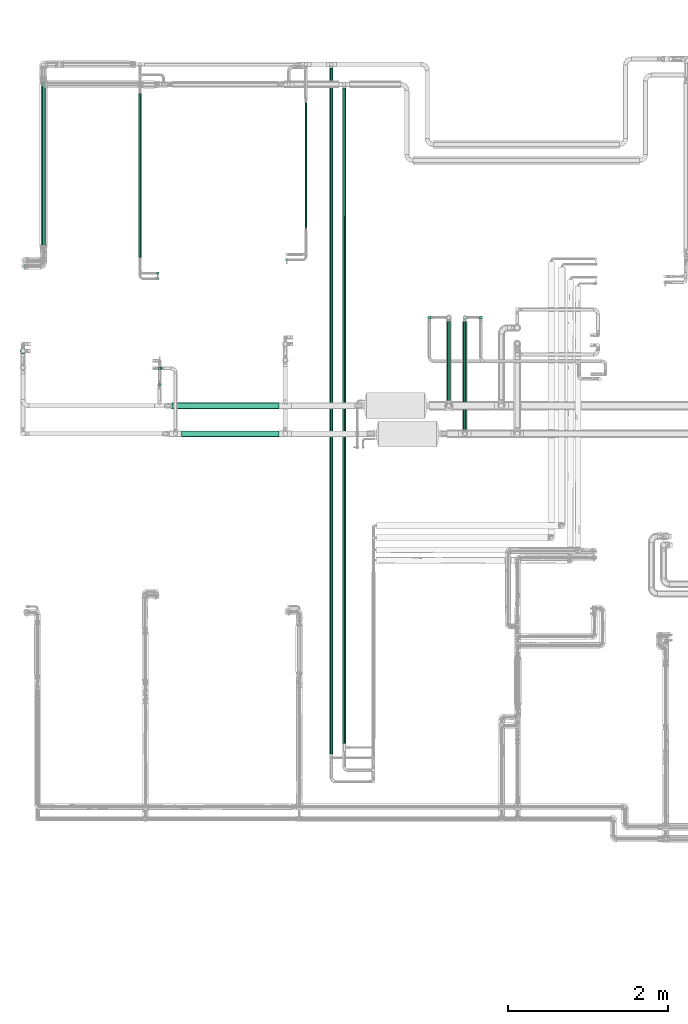
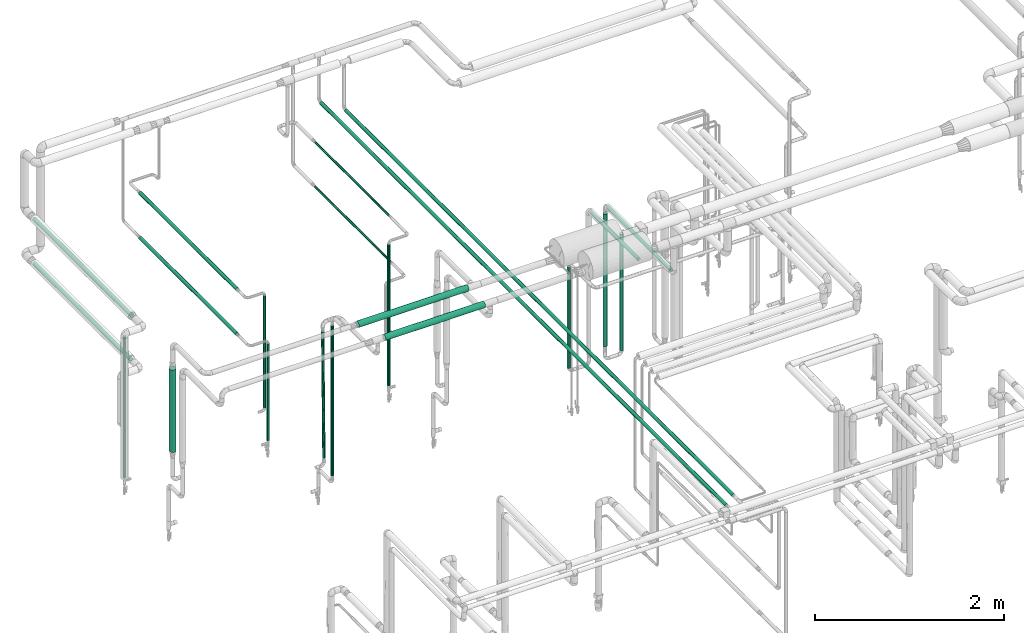
# One storey, part 524 of 827: 22 flow segments.
"""IFC2X3 building model written with IfcOpenShell, lengths in millimetres."""

from ifc_helpers import new_model, entity, si_unit, converted_unit, derived_unit, direction, frame, origin, origin_2d_with_axis, place, context, subcontext, project, spatial, circle, extrude, type_object, element, save


model = new_model("IFC2X3")

# Units and contexts
model_context = context("Model", 3, precision=0.01, world=origin(), true_north=direction((6.12303176911189e-17, 1.0)))
body_context = subcontext(model_context, "Body", "Model", "MODEL_VIEW")
ifc_project = project(units=[si_unit("LENGTHUNIT", "METRE", prefix="MILLI"), si_unit("AREAUNIT", "SQUARE_METRE"), si_unit("VOLUMEUNIT", "CUBIC_METRE"), converted_unit("PLANEANGLEUNIT", "DEGREE", entity("IfcRatioMeasure", 0.0174532925199433), si_unit("PLANEANGLEUNIT", "RADIAN"), dimensions=[0, 0, 0, 0, 0, 0, 0]), si_unit("MASSUNIT", "GRAM", prefix="KILO"), derived_unit("MASSDENSITYUNIT", [(si_unit("MASSUNIT", "GRAM", prefix="KILO"), 1), (si_unit("LENGTHUNIT", "METRE"), -3)]), derived_unit("MOMENTOFINERTIAUNIT", [(si_unit("LENGTHUNIT", "METRE"), 4)]), si_unit("TIMEUNIT", "SECOND"), si_unit("FREQUENCYUNIT", "HERTZ"), si_unit("THERMODYNAMICTEMPERATUREUNIT", "DEGREE_CELSIUS"), derived_unit("THERMALTRANSMITTANCEUNIT", [(si_unit("MASSUNIT", "GRAM", prefix="KILO"), 1), (si_unit("THERMODYNAMICTEMPERATUREUNIT", "KELVIN"), -1), (si_unit("TIMEUNIT", "SECOND"), -3)]), derived_unit("VOLUMETRICFLOWRATEUNIT", [(si_unit("LENGTHUNIT", "METRE"), 3), (si_unit("TIMEUNIT", "SECOND"), -1)]), derived_unit("MASSFLOWRATEUNIT", [(si_unit("MASSUNIT", "GRAM", prefix="KILO"), 1), (si_unit("TIMEUNIT", "SECOND"), -1)]), derived_unit("ROTATIONALFREQUENCYUNIT", [(si_unit("TIMEUNIT", "SECOND"), -1)]), si_unit("ELECTRICCURRENTUNIT", "AMPERE"), si_unit("ELECTRICVOLTAGEUNIT", "VOLT"), si_unit("POWERUNIT", "WATT"), si_unit("FORCEUNIT", "NEWTON", prefix="KILO"), si_unit("ILLUMINANCEUNIT", "LUX"), si_unit("LUMINOUSFLUXUNIT", "LUMEN"), si_unit("LUMINOUSINTENSITYUNIT", "CANDELA"), derived_unit("USERDEFINED", [(si_unit("MASSUNIT", "GRAM", prefix="KILO"), -1), (si_unit("LENGTHUNIT", "METRE"), -2), (si_unit("TIMEUNIT", "SECOND"), 3), (si_unit("LUMINOUSFLUXUNIT", "LUMEN"), 1)]), derived_unit("LINEARVELOCITYUNIT", [(si_unit("LENGTHUNIT", "METRE"), 1), (si_unit("TIMEUNIT", "SECOND"), -1)]), si_unit("PRESSUREUNIT", "PASCAL"), derived_unit("USERDEFINED", [(si_unit("LENGTHUNIT", "METRE"), -2), (si_unit("MASSUNIT", "GRAM", prefix="KILO"), 1), (si_unit("TIMEUNIT", "SECOND"), -2)]), derived_unit("LINEARFORCEUNIT", [(si_unit("MASSUNIT", "GRAM", prefix="KILO"), 1), (si_unit("LENGTHUNIT", "METRE"), 1), (si_unit("TIMEUNIT", "SECOND"), -2), (si_unit("LENGTHUNIT", "METRE"), -1)]), derived_unit("PLANARFORCEUNIT", [(si_unit("MASSUNIT", "GRAM", prefix="KILO"), 1), (si_unit("LENGTHUNIT", "METRE"), 1), (si_unit("TIMEUNIT", "SECOND"), -2), (si_unit("LENGTHUNIT", "METRE"), -2)])], contexts=[model_context])

# Site, building, storey
site_placement = place(None, origin())
site = spatial("IfcSite", under=ifc_project, at=site_placement, CompositionType="ELEMENT")
building_placement = place(site_placement, origin())
building = spatial("IfcBuilding", under=site, at=building_placement, CompositionType="ELEMENT")
storey_placement = place(building_placement, frame((0.0, 0.0, 28200.0)))
storey = spatial("IfcBuildingStorey", under=building, at=storey_placement, Name="08", CompositionType="ELEMENT", Elevation=28200.0)

# Flow segments
pipe_segment_type = type_object("IfcPipeSegmentType", PredefinedType="NOTDEFINED")
flow_segment_1_placement = place(storey_placement, frame((11756.87, 16476.3, 407.5)))
element("IfcFlowSegment", 1, at=flow_segment_1_placement, inside=storey, type_object=pipe_segment_type, context=body_context, shape_type="SweptSolid", body=[
    extrude(circle(Radius=16.75, at=origin_2d_with_axis()), frame((18.35, 18.35, 0.0), z_axis=(0.0, 0.0, 1.0), x_axis=(-1.0, 0.0, 0.0)), (0.0, 0.0, 1.0), 1824.7853679055),
])
flow_segment_2_placement = place(storey_placement, frame((13415.62, 16387.05, 788.0)))
element("IfcFlowSegment", 2, at=flow_segment_2_placement, inside=storey, type_object=pipe_segment_type, context=body_context, shape_type="SweptSolid", body=[
    extrude(circle(Radius=16.75, at=origin_2d_with_axis()), frame((18.35, 18.35, 0.0), z_axis=(0.0, 1.18738116204354e-05, 1.0), x_axis=(-1.0, 0.0, 0.0)), (0.0, 0.0, 1.0), 1444.28268558114),
])
flow_segment_3_placement = place(storey_placement, frame((15026.3, 16554.55, 407.5)))
element("IfcFlowSegment", 3, at=flow_segment_3_placement, inside=storey, type_object=pipe_segment_type, context=body_context, shape_type="SweptSolid", body=[
    extrude(circle(Radius=16.75, at=origin_2d_with_axis()), frame((18.35, 18.35, 0.0), z_axis=(0.0, 0.0, 1.0), x_axis=(-1.0, 0.0, 0.0)), (0.0, 0.0, 1.0), 1819.95737347912),
])
flow_segment_4_placement = place(storey_placement, frame((13415.62, 16319.55, 407.5)))
element("IfcFlowSegment", 4, at=flow_segment_4_placement, inside=storey, type_object=pipe_segment_type, context=body_context, shape_type="SweptSolid", body=[
    extrude(circle(Radius=16.75, at=origin_2d_with_axis()), frame((18.35, 18.35, 0.0)), (0.0, 0.0, 1.0), 1247.16067111276),
])
flow_segment_5_placement = place(storey_placement, frame((15578.81, 10401.48, 2379.31)))
element("IfcFlowSegment", 5, at=flow_segment_5_placement, inside=storey, type_object=pipe_segment_type, context=body_context, shape_type="SweptSolid", body=[
    extrude(circle(Radius=21.15, at=origin_2d_with_axis()), frame((22.75, 0.0, 22.75), z_axis=(0.0, 1.0, 0.0), x_axis=(-1.0, 0.0, 0.0)), (0.0, 0.0, 1.0), 8563.32413915091),
])
flow_segment_6_placement = place(storey_placement, frame((13608.97, 14710.55, 2760.65)))
element("IfcFlowSegment", 6, at=flow_segment_6_placement, inside=storey, type_object=pipe_segment_type, context=body_context, shape_type="SweptSolid", body=[
    extrude(circle(Radius=37.75, at=origin_2d_with_axis()), frame((0.0, 39.35, 39.35), z_axis=(1.0, 0.0, 0.0), x_axis=(0.0, -1.0, 0.0)), (0.0, 0.0, 1.0), 1340.98491580732),
])
flow_segment_7_placement = place(storey_placement, frame((17445.46, 15829.04, 451.86)))
element("IfcFlowSegment", 7, at=flow_segment_7_placement, inside=storey, type_object=pipe_segment_type, context=body_context, shape_type="SweptSolid", body=[
    extrude(circle(Radius=21.15, at=origin_2d_with_axis()), frame((22.75, 22.75, 0.0)), (0.0, 0.0, 1.0), 1500.14499819194),
])
flow_segment_8_placement = place(storey_placement, frame((16802.89, 15829.04, 451.94)))
element("IfcFlowSegment", 8, at=flow_segment_8_placement, inside=storey, type_object=pipe_segment_type, context=body_context, shape_type="SweptSolid", body=[
    extrude(circle(Radius=21.15, at=origin_2d_with_axis()), frame((22.75, 22.75, 0.0), z_axis=(0.0, 0.0, 1.0), x_axis=(-1.0, 0.0, 0.0)), (0.0, 0.0, 1.0), 1300.06431381678),
])
flow_segment_9_placement = place(storey_placement, frame((17045.62, 14797.79, 2377.25)))
element("IfcFlowSegment", 9, at=flow_segment_9_placement, inside=storey, type_object=pipe_segment_type, context=body_context, shape_type="SweptSolid", body=[
    extrude(circle(Radius=21.15, at=origin_2d_with_axis()), frame((22.75, 0.0, 22.75), z_axis=(0.0, 1.0, 0.0), x_axis=(-1.0, 0.0, 0.0)), (0.0, 0.0, 1.0), 1005.99246062177),
])
flow_segment_10_placement = place(storey_placement, frame((17243.97, 14448.0, 2377.25)))
element("IfcFlowSegment", 10, at=flow_segment_10_placement, inside=storey, type_object=pipe_segment_type, context=body_context, shape_type="SweptSolid", body=[
    extrude(circle(Radius=21.15, at=origin_2d_with_axis()), frame((22.75, 0.0, 22.75), z_axis=(0.0, 1.0, 0.0), x_axis=(1.0, 0.0, 0.0)), (0.0, 0.0, 1.0), 1355.78810636395),
])
flow_segment_11_placement = place(storey_placement, frame((15738.14, 10529.41, 2377.25)))
element("IfcFlowSegment", 11, at=flow_segment_11_placement, inside=storey, type_object=pipe_segment_type, context=body_context, shape_type="SweptSolid", body=[
    extrude(circle(Radius=21.15, at=origin_2d_with_axis()), frame((22.75, 0.0, 22.75), z_axis=(7.11924808198601e-06, 1.0, 1.26267666241886e-06), x_axis=(1.0, -7.11924808199168e-06, 0.0)), (0.0, 0.0, 1.0), 8185.56684319183),
])
flow_segment_12_placement = place(storey_placement, frame((17241.12, 15826.19, 574.2)))
element("IfcFlowSegment", 12, at=flow_segment_12_placement, inside=storey, type_object=pipe_segment_type, context=body_context, shape_type="SweptSolid", body=[
    extrude(circle(Radius=24.0, at=origin_2d_with_axis()), frame((25.6, 25.6, 0.0), z_axis=(0.0, 0.0, 1.0), x_axis=(-1.0, 0.0, 0.0)), (0.0, 0.0, 1.0), 1713.79999999998),
])
flow_segment_13_placement = place(storey_placement, frame((11979.87, 16731.69, 2244.69)))
element("IfcFlowSegment", 13, at=flow_segment_13_placement, inside=storey, type_object=pipe_segment_type, context=body_context, shape_type="SweptSolid", body=[
    extrude(circle(Radius=24.0, at=origin_2d_with_axis()), frame((25.6, 0.0, 25.6), z_axis=(0.0, 1.0, 0.0), x_axis=(-1.0, 0.0, 0.0)), (0.0, 0.0, 1.0), 2064.72931793336),
])
flow_segment_14_placement = place(storey_placement, frame((11980.35, 16759.86, 1668.67)))
element("IfcFlowSegment", 14, at=flow_segment_14_placement, inside=storey, type_object=pipe_segment_type, context=body_context, shape_type="SweptSolid", body=[
    extrude(circle(Radius=24.0, at=origin_2d_with_axis()), frame((25.6, 0.0, 25.6), z_axis=(0.0, 1.0, 0.0), x_axis=(1.0, 0.0, 0.0)), (0.0, 0.0, 1.0), 2034.37525687381),
])
flow_segment_15_placement = place(storey_placement, frame((11711.61, 15395.86, 1409.16)))
element("IfcFlowSegment", 15, at=flow_segment_15_placement, inside=storey, type_object=pipe_segment_type, context=body_context, shape_type="SweptSolid", body=[
    extrude(circle(Radius=37.75, at=origin_2d_with_axis()), frame((39.35, 39.35, 0.0)), (0.0, 0.0, 1.0), 1062.53136734864),
])
flow_segment_16_placement = place(storey_placement, frame((13188.22, 16596.41, 2247.49)))
element("IfcFlowSegment", 16, at=flow_segment_16_placement, inside=storey, type_object=pipe_segment_type, context=body_context, shape_type="SweptSolid", body=[
    extrude(circle(Radius=21.15, at=origin_2d_with_axis()), frame((22.75, 0.0, 22.75), z_axis=(0.0, 1.0, 4.87503029202243e-06), x_axis=(1.0, 0.0, 0.0)), (0.0, 0.0, 1.0), 2053.46541931569),
])
flow_segment_17_placement = place(storey_placement, frame((13188.22, 16598.9, 1669.92)))
element("IfcFlowSegment", 17, at=flow_segment_17_placement, inside=storey, type_object=pipe_segment_type, context=body_context, shape_type="SweptSolid", body=[
    extrude(circle(Radius=21.15, at=origin_2d_with_axis()), frame((22.75, 0.0, 22.75), z_axis=(0.0, 1.0, 0.0), x_axis=(1.0, 0.0, 0.0)), (0.0, 0.0, 1.0), 2047.85020105494),
])
flow_segment_18_placement = place(storey_placement, frame((13437.62, 14996.86, 749.0)))
element("IfcFlowSegment", 18, at=flow_segment_18_placement, inside=storey, type_object=pipe_segment_type, context=body_context, shape_type="SweptSolid", body=[
    extrude(circle(Radius=16.75, at=origin_2d_with_axis()), frame((18.35, 18.35, 0.0), z_axis=(0.0, 0.0, 1.0), x_axis=(-1.0, 0.0, 0.0)), (0.0, 0.0, 1.0), 1930.00000000002),
])
flow_segment_19_placement = place(storey_placement, frame((13437.62, 15199.55, 848.84)))
element("IfcFlowSegment", 19, at=flow_segment_19_placement, inside=storey, type_object=pipe_segment_type, context=body_context, shape_type="SweptSolid", body=[
    extrude(circle(Radius=16.75, at=origin_2d_with_axis()), frame((33.65, 18.35, 0.16), z_axis=(-0.00939157657894753, 0.0, 0.999955898172195), x_axis=(0.0, -1.0, 0.0)), (0.0, 0.0, 1.0), 1630.07188914978),
])
flow_segment_20_placement = place(storey_placement, frame((13731.95, 14360.65, 2760.62)))
element("IfcFlowSegment", 20, at=flow_segment_20_placement, inside=storey, type_object=pipe_segment_type, context=body_context, shape_type="SweptSolid", body=[
    extrude(circle(Radius=37.75, at=origin_2d_with_axis()), frame((0.0, 39.35, 39.35), z_axis=(1.0, 0.0, 0.0), x_axis=(0.0, 1.0, 0.0)), (0.0, 0.0, 1.0), 1217.99999999998),
])
flow_segment_21_placement = place(storey_placement, frame((15268.52, 16977.0, 2250.46)))
element("IfcFlowSegment", 21, at=flow_segment_21_placement, inside=storey, type_object=pipe_segment_type, context=body_context, shape_type="SweptSolid", body=[
    extrude(circle(Radius=13.4, at=origin_2d_with_axis()), frame((15.0, 0.0, 15.0), z_axis=(0.0, 1.0, 0.0), x_axis=(-1.0, 0.0, 0.0)), (0.0, 0.0, 1.0), 1554.97908997249),
])
flow_segment_22_placement = place(storey_placement, frame((15268.52, 16950.73, 1675.71)))
element("IfcFlowSegment", 22, at=flow_segment_22_placement, inside=storey, type_object=pipe_segment_type, context=body_context, shape_type="SweptSolid", body=[
    extrude(circle(Radius=13.4, at=origin_2d_with_axis()), frame((15.0, 0.0, 15.0), z_axis=(0.0, 1.0, 0.0), x_axis=(1.0, 0.0, 0.0)), (0.0, 0.0, 1.0), 1591.76047656877),
])

save(model, "model.ifc")
